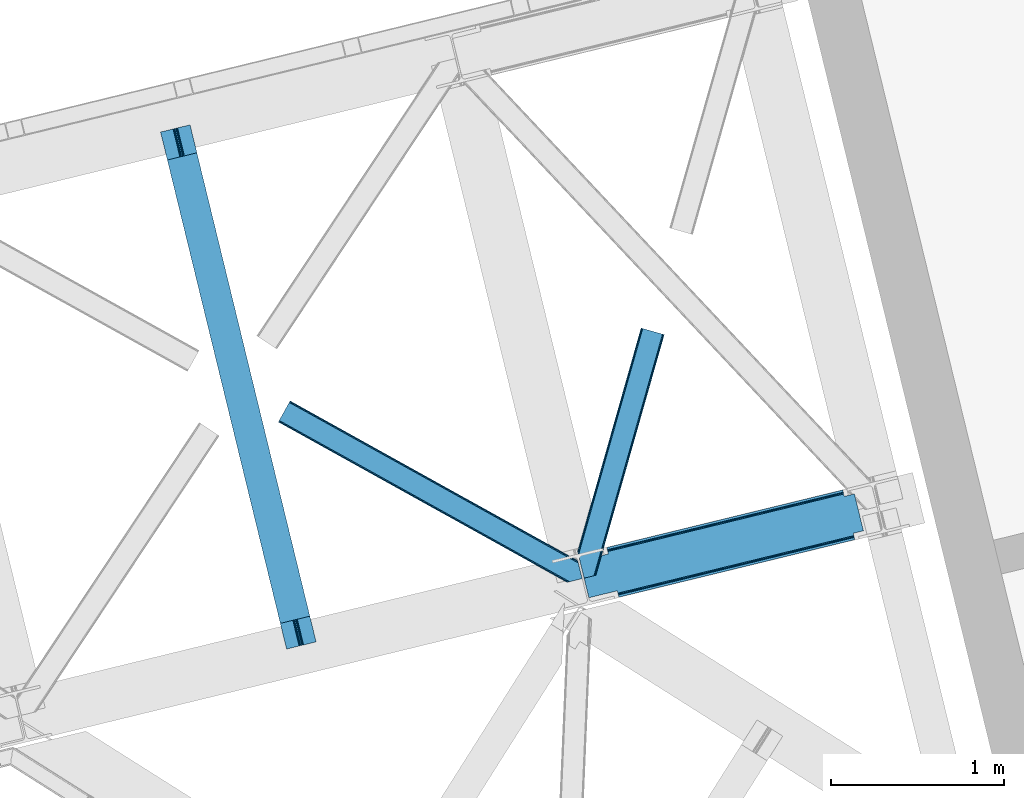
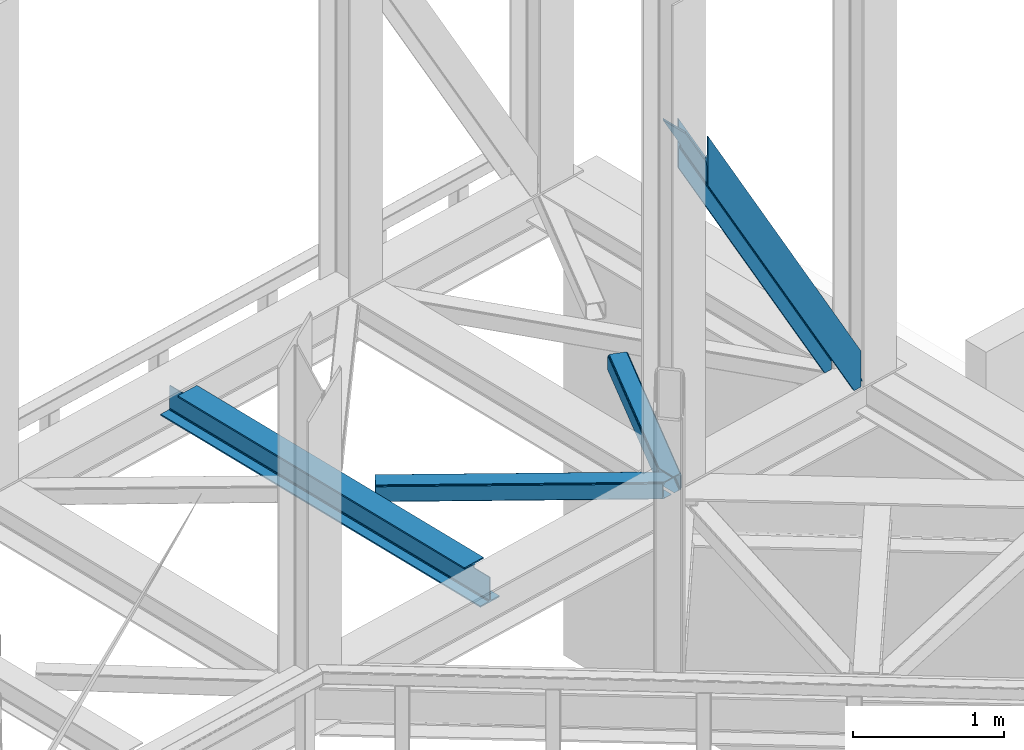
# One storey, part 83 of 92: 3 members, 1 beam.
"""IFC4 building model written with IfcOpenShell, lengths in millimetres."""

from ifc_helpers import new_model, entity, si_unit, converted_unit, derived_unit, direction, frame, origin, place, context, subcontext, project, spatial, triangles, polygons, material, type_object, element, save


model = new_model("IFC4")

# Units and contexts
model_context = context("Model", 3, precision=0.01, world=origin(), true_north=direction((6.12303176911189e-17, 1.0)))
plan_context = context("Plan", 3, precision=0.01, world=origin(), true_north=direction((6.12303176911189e-17, 1.0)))
body_context = subcontext(model_context, "Body", "Model", "MODEL_VIEW")
ifc_project = project(units=[si_unit("LENGTHUNIT", "METRE", prefix="MILLI"), si_unit("AREAUNIT", "SQUARE_METRE"), si_unit("VOLUMEUNIT", "CUBIC_METRE"), converted_unit("PLANEANGLEUNIT", "DEGREE", entity("IfcRatioMeasure", 0.0174532925199433), si_unit("PLANEANGLEUNIT", "RADIAN"), dimensions=[0, 0, 0, 0, 0, 0, 0]), si_unit("MASSUNIT", "GRAM", prefix="KILO"), derived_unit("MASSDENSITYUNIT", [(si_unit("MASSUNIT", "GRAM", prefix="KILO"), 1), (si_unit("LENGTHUNIT", "METRE"), -3)]), derived_unit("MOMENTOFINERTIAUNIT", [(si_unit("LENGTHUNIT", "METRE"), 4)]), si_unit("TIMEUNIT", "SECOND"), si_unit("FREQUENCYUNIT", "HERTZ"), si_unit("THERMODYNAMICTEMPERATUREUNIT", "DEGREE_CELSIUS"), derived_unit("THERMALTRANSMITTANCEUNIT", [(si_unit("MASSUNIT", "GRAM", prefix="KILO"), 1), (si_unit("THERMODYNAMICTEMPERATUREUNIT", "KELVIN"), -1), (si_unit("TIMEUNIT", "SECOND"), -3)]), derived_unit("VOLUMETRICFLOWRATEUNIT", [(si_unit("LENGTHUNIT", "METRE"), 3), (si_unit("TIMEUNIT", "SECOND"), -1)]), derived_unit("MASSFLOWRATEUNIT", [(si_unit("MASSUNIT", "GRAM", prefix="KILO"), 1), (si_unit("TIMEUNIT", "SECOND"), -1)]), derived_unit("ROTATIONALFREQUENCYUNIT", [(si_unit("TIMEUNIT", "SECOND"), -1)]), si_unit("ELECTRICCURRENTUNIT", "AMPERE"), si_unit("ELECTRICVOLTAGEUNIT", "VOLT"), si_unit("POWERUNIT", "WATT"), si_unit("FORCEUNIT", "NEWTON", prefix="KILO"), si_unit("ILLUMINANCEUNIT", "LUX"), si_unit("LUMINOUSFLUXUNIT", "LUMEN"), si_unit("LUMINOUSINTENSITYUNIT", "CANDELA"), derived_unit("USERDEFINED", [(si_unit("MASSUNIT", "GRAM", prefix="KILO"), -1), (si_unit("LENGTHUNIT", "METRE"), -2), (si_unit("TIMEUNIT", "SECOND"), 3), (si_unit("LUMINOUSFLUXUNIT", "LUMEN"), 1)]), derived_unit("LINEARVELOCITYUNIT", [(si_unit("LENGTHUNIT", "METRE"), 1), (si_unit("TIMEUNIT", "SECOND"), -1)]), si_unit("PRESSUREUNIT", "PASCAL"), derived_unit("USERDEFINED", [(si_unit("LENGTHUNIT", "METRE"), -2), (si_unit("MASSUNIT", "GRAM", prefix="KILO"), 1), (si_unit("TIMEUNIT", "SECOND"), -2)]), derived_unit("LINEARFORCEUNIT", [(si_unit("MASSUNIT", "GRAM", prefix="KILO"), 1), (si_unit("LENGTHUNIT", "METRE"), 1), (si_unit("TIMEUNIT", "SECOND"), -2), (si_unit("LENGTHUNIT", "METRE"), -1)]), derived_unit("PLANARFORCEUNIT", [(si_unit("MASSUNIT", "GRAM", prefix="KILO"), 1), (si_unit("LENGTHUNIT", "METRE"), 1), (si_unit("TIMEUNIT", "SECOND"), -2), (si_unit("LENGTHUNIT", "METRE"), -2)])], contexts=[model_context, plan_context])

# Site, building, storey
site_placement = place(None, origin())
site = spatial("IfcSite", under=ifc_project, at=site_placement, CompositionType="ELEMENT")
building_placement = place(site_placement, origin())
building = spatial("IfcBuilding", under=site, at=building_placement, CompositionType="ELEMENT")
storey_placement = place(building_placement, frame((0.0, 0.0, 15900.0)))
storey = spatial("IfcBuildingStorey", under=building, at=storey_placement, Name="05", CompositionType="ELEMENT", Elevation=15900.0)

# Beam
ifc_material = material(Name="Metal painted (White)")
beam_type = type_object("IfcBeamType", PredefinedType="BEAM")
beam_placement = place(storey_placement, frame((-4605.05, 16672.4, 3441.0)))
element("IfcBeam", 1, at=beam_placement, inside=storey, type_object=beam_type, material=ifc_material, ObjectType="Steel Beam", PredefinedType="BEAM", context=body_context, shape_type="Tessellation", body=[
    polygons([(896.722476515621, 41.4445662733103, 11.000000000004), (896.72247651562, 41.4445662733103, 2.16573425859679e-12), (170.02161017477, 3022.65205668042, 2.16573425859679e-12), (170.02161017477, 3022.65205668042, 11.000000000004), (830.656936562001, 25.3403919499699, 11.000000000004), (103.95607022115, 3006.54788235708, 11.000000000004), (824.708186540703, 23.8903211957417, 12.2179274798217), (98.007320199853, 3005.09781160286, 12.2179274798217), (819.665079784591, 22.6610105689216, 15.6862915010257), (92.9642134437405, 3003.86850097604, 15.6862915010257), (816.295383581418, 21.839611468714, 20.8770650821657), (89.5945172405684, 3003.04710187583, 20.8770650821657), (815.112103631724, 21.5511744621227, 27.0000000000047), (88.4112372908739, 3002.75866486924, 27.0000000000047), (81.6103728838909, 3001.1008822183, 27.0000000000047), (81.6103728838915, 3001.10088221831, 203.000000000006), (88.4112372908706, 3002.75866486924, 203.000000000006), (5.41433564649196e-13, 2981.20749040711, 2.16573425859679e-12), (2.16573425859679e-12, 2981.20749040711, 10.9999999999997), (66.0655399536302, 2997.31166473046, 11.000000000004), (72.0142899749205, 2998.76173548468, 12.2179274798195), (77.0573967310308, 2999.99104611151, 15.6862915010192), (80.427092934211, 3000.81244521171, 20.8770650821657), (815.112103631721, 21.5511744621206, 203.000000000006), (808.311239224742, 19.8933918111897, 203.000000000006), (808.311239224741, 19.8933918111897, 27.0000000000047), (807.127959275061, 19.6049548046028, 20.8770650821657), (803.75826307188, 18.7835557043952, 15.6862915010192), (798.71515631577, 17.5542450775707, 12.2179274798195), (792.76640629448, 16.104174323349, 11.000000000004), (726.700866340852, 2.16573425859679e-12, 10.9999999999997), (726.700866340851, 2.16573425859679e-12, 2.16573425859679e-12), (779.142354126241, 169.113117828151, 203.069793472056), (127.487542634277, 2842.45257527589, 203.000000000006), (127.710423423425, 2841.53823284147, 203.617301946336), (127.723337667946, 2841.48525286857, 217.000003693143), (778.997150924595, 169.708652488344, 217.000003676718), (778.998021532492, 169.705081047464, 204.00000679514), (772.432053048639, 167.083518913905, 203.006342977999), (772.209205347559, 167.99787105405, 203.617301946336), (772.196291103036, 168.050851026943, 217.000003693143), (120.922477846387, 2839.82745140717, 217.000003676718), (120.921607238492, 2839.83102284805, 204.00000679514), (120.77730764944, 2840.42299574862, 203.076120467494), (120.686678227296, 2840.79479262496, 203.000000000006), (780.180635648643, 169.996249461788, 223.122939328039), (783.549632057316, 170.820519285667, 228.313710402595), (788.592267461342, 172.051763510973, 231.782072735464), (794.540846332051, 173.502536365655, 232.999999602236), (860.606297197569, 189.607076149589, 232.999999283132), (860.604823861134, 189.613120126462, 243.999994005812), (690.583442957211, 148.167613329572, 243.999994827032), (690.58491629365, 148.161569352698, 233.000000104353), (756.650367159178, 164.266109136635, 232.999999785253), (762.599272287504, 165.715543604856, 231.782072861016), (767.642836794641, 166.94297642799, 228.313710479427), (771.01322370438, 167.761542085424, 223.12293937232), (119.738993122354, 2839.53985443373, 223.122939328039), (116.369996713678, 2838.71558460985, 228.313710402595), (111.327361309646, 2837.48434038454, 231.782072735464), (105.378782438949, 2836.03356752986, 232.999999602236), (39.3133315734155, 2819.92902774593, 232.999999283128), (39.3148049098525, 2819.92298376905, 243.999994005812), (209.336185813776, 2861.36849056595, 243.999994827032), (209.334712477334, 2861.37453454282, 233.000000104357), (143.269261611822, 2845.26999475889, 232.999999785253), (137.320356483485, 2843.82056029066, 231.782072861012), (132.276791976353, 2842.59312746752, 228.313710479427), (128.906405066617, 2841.77456181009, 223.12293937232)], [[[1, 2, 3, 4]], [[5, 1, 4, 6]], [[7, 5, 6, 8]], [[9, 7, 8, 10]], [[11, 9, 10, 12]], [[13, 11, 12, 14]], [[15, 16, 17, 14, 12, 10, 8, 6, 4, 3, 18, 19, 20, 21, 22, 23]], [[13, 24, 25, 26, 27, 28, 29, 30, 31, 32, 2, 1, 5, 7, 9, 11]], [[2, 32, 18, 3]], [[32, 31, 19, 18]], [[31, 30, 20, 19]], [[27, 26, 15, 23]], [[28, 27, 23, 22]], [[29, 28, 22, 21]], [[30, 29, 21, 20]], [[33, 24, 13, 14, 17, 34, 35, 36, 37, 38]], [[25, 39, 40, 41, 42, 43, 44, 16, 15, 26]], [[39, 25, 24, 33]], [[45, 34, 17, 16]], [[41, 40, 38, 37, 46, 47, 48, 49, 50, 51, 52, 53, 54, 55, 56, 57]], [[42, 58, 59, 60, 61, 62, 63, 64, 65, 66, 67, 68, 69, 36, 35, 43]], [[46, 37, 36, 69]], [[47, 46, 69, 68]], [[48, 47, 68, 67]], [[49, 48, 67, 66]], [[50, 49, 66, 65]], [[51, 50, 65, 64]], [[52, 51, 64, 63]], [[53, 52, 63, 62]], [[54, 53, 62, 61]], [[55, 54, 61, 60]], [[56, 55, 60, 59]], [[57, 56, 59, 58]], [[41, 57, 58, 42]]], closed=False),
])

# Members
member_type_1 = type_object("IfcMemberType", PredefinedType="BRACE")
member_1_placement = place(storey_placement, frame((-2187.22, 16968.36, 3695.0)))
element("IfcMember", 2, at=member_1_placement, inside=storey, type_object=member_type_1, ObjectType="Steel Vertical Brace", PredefinedType="BRACE", context=body_context, shape_type="Tessellation", body=[
    polygons([(1523.65378747275, 333.032085942706, 0.0), (1582.15074591361, 347.2913384483, 0.0), (1585.22948512248, 334.661161692462, 0.0), (1526.73252668162, 320.401909186869, 0.0), (225.056603724429, 3.10463150599028, 2308.00987734577), (221.977864515554, 15.734808261831, 2308.00987734577), (221.977864515553, 15.734808261831, 2462.87833808595), (1582.1507459136, 347.291338448298, 51.1471308030944), (225.056603724427, 3.10463150599028, 2706.38533905685), (1585.22948512248, 334.661161692462, 294.654131773986), (217.71499484172, 33.2227453083746, 2515.66308676267), (216.294038283785, 39.0520576572275, 2515.66308676267), (216.294038283786, 39.0520576572275, 2498.73212963995), (217.714994841717, 33.2227453083768, 2498.73212963995), (219.34632444024, 26.5304015344206, 2496.00292226562), (220.72929889541, 20.8569064337962, 2488.23079722503), (221.653372883133, 17.065998205232, 2476.59899010114), (221.977864515552, 15.734808261831, 2706.38533905685), (221.977864515552, 15.734808261831, 2551.51687831667), (221.653372883138, 17.0659982052385, 2537.79622630148), (220.729298895404, 20.856906433807, 2526.16441917759), (219.346324440226, 26.5304015344141, 2518.39229413699), (1576.46691968183, 370.608587843693, 87.0009223570892), (1576.46691968183, 370.608587843693, 103.931879479809), (1577.88787623976, 364.779275494842, 103.9318794798), (1579.51920583827, 358.086931720883, 106.661086854137), (1580.90218029345, 352.413436620276, 114.433211894731), (1581.82625428118, 348.622528391703, 126.065019018618), (1582.15074591359, 347.291338448298, 139.785671033808), (1582.15074591359, 347.291338448298, 294.654131773986), (1581.82625428118, 348.622528391697, 64.8677828182753), (1580.90218029345, 352.413436620263, 76.4995899421711), (1579.51920583828, 358.086931720888, 84.2717149827655), (1577.88787623976, 364.779275494846, 87.0009223570848), (163.955471732923, 253.765062506492, 2498.73212963995), (162.534515174981, 259.594374855341, 2498.73212963995), (1522.70739657303, 591.15090504181, 87.0009223570935), (1524.12835313097, 585.321592692961, 87.0009223570935), (1524.73254220655, 584.95422971039, 86.1395897830593), (1525.33673128212, 584.586866727814, 85.2782572090295), (1573.43212950823, 596.310628884719, 0.0), (1625.29704387311, 383.540728151737, 0.0), (1577.201645647, 371.81696599483, 85.2782572090295), (1576.83428266443, 371.212776919264, 86.1395897830593), (215.689849208223, 39.4194206398013, 2499.59346221398), (215.085660132657, 39.7867836223773, 2500.45479478801), (51.8649143648901, 2.16573425859679e-12, 2789.86253966195), (6.76791955811495e-12, 212.769900732984, 2789.86253966195), (163.220745767773, 252.556684355359, 2500.45479478801), (163.588108750349, 253.160873430927, 2499.59346221398), (163.220745767771, 252.556684355359, 2517.38575191073), (5.41433564649196e-13, 212.769900732984, 2806.79349678468), (51.8649143648844, 0.0, 2806.79349678468), (215.085660132655, 39.7867836223773, 2517.38575191073), (215.68984920822, 39.4194206398013, 2516.5244193367), (1576.83428266442, 371.212776919264, 103.070546905779), (1577.201645647, 371.81696599483, 102.209214331749), (1634.84579817246, 385.868338036035, 0.0), (1582.98088380758, 598.638238769017, 0.0), (1525.33673128211, 584.586866727814, 102.209214331749), (1524.73254220655, 584.954229710388, 103.070546905779), (1524.12835313097, 585.321592692961, 103.931879479813), (1522.70739657303, 591.15090504181, 103.931879479809), (162.534515174979, 259.594374855341, 2515.66308676267), (163.955471732921, 253.765062506492, 2515.66308676267), (163.588108750346, 253.160873430927, 2516.5244193367), (160.903185576473, 266.286718629297, 2518.39229413699), (159.520211121304, 271.960213729915, 2526.16441917758), (158.596137133563, 275.751121958494, 2537.79622630147), (158.271645501151, 277.082311901891, 2551.51687831666), (158.271645501151, 277.082311901886, 2706.38533905685), (155.192906292277, 289.712488657727, 2706.38533905685), (155.192906292278, 289.712488657727, 2308.00987734577), (158.271645501152, 277.082311901886, 2308.00987734577), (158.271645501151, 277.082311901886, 2462.87833808595), (158.596137133566, 275.75112195849, 2476.59899010114), (159.520211121302, 271.960213729923, 2488.23079722503), (160.903185576474, 266.286718629303, 2496.00292226561), (1521.07606697452, 597.843248815768, 84.2717149827568), (1519.69309251934, 603.516743916388, 76.4995899421711), (1518.76901853161, 607.307652144959, 64.8677828182753), (1518.44452689919, 608.638842088356, 51.1471308030858), (1518.44452689919, 608.638842088356, 0.0), (1515.36578769032, 621.269018844194, 0.0), (1515.36578769032, 621.269018844194, 294.654131773986), (1518.44452689919, 608.638842088356, 294.654131773986), (1518.44452689919, 608.638842088358, 139.785671033799), (1518.76901853161, 607.307652144961, 126.065019018618), (1519.69309251935, 603.516743916384, 114.433211894731), (1521.07606697452, 597.843248815764, 106.661086854141), (1459.94756845834, 594.379589582763, 0.0), (1456.86882924947, 607.009766338602, 0.0)], [[[1, 2, 3, 4]], [[5, 6, 1, 4]], [[6, 7, 8, 2, 1]], [[9, 5, 4, 3, 10]], [[11, 12, 13, 14, 15, 16, 17, 7, 6, 5, 9, 18, 19, 20, 21, 22]], [[23, 24, 25, 26, 27, 28, 29, 30, 10, 3, 2, 8, 31, 32, 33, 34]], [[34, 33, 15, 14]], [[33, 32, 16, 15]], [[32, 31, 17, 16]], [[31, 8, 7, 17]], [[18, 9, 10, 30]], [[19, 18, 30, 29]], [[29, 28, 20, 19]], [[28, 27, 21, 20]], [[27, 26, 22, 21]], [[26, 25, 11, 22]], [[35, 36, 37, 38, 39, 40, 41, 42, 43, 44, 23, 34, 14, 13, 45, 46, 47, 48, 49, 50]], [[51, 52, 53, 54, 55, 12, 11, 25, 24, 56, 57, 58, 59, 60, 61, 62, 63, 64, 65, 66]], [[54, 53, 47, 46]], [[48, 47, 53, 52]], [[52, 51, 49, 48]], [[57, 43, 42, 58]], [[59, 58, 42, 41]], [[59, 41, 40, 60]], [[65, 64, 67, 68, 69, 70, 71, 72, 73, 74, 75, 76, 77, 78, 36, 35]], [[62, 38, 37, 79, 80, 81, 82, 83, 84, 85, 86, 87, 88, 89, 90, 63]], [[82, 81, 76, 75]], [[81, 80, 77, 76]], [[80, 79, 78, 77]], [[79, 37, 36, 78]], [[75, 74, 91, 83, 82]], [[92, 84, 83, 91]], [[74, 73, 92, 91]], [[73, 72, 85, 84, 92]], [[63, 90, 67, 64]], [[90, 89, 68, 67]], [[89, 88, 69, 68]], [[88, 87, 70, 69]], [[71, 70, 87, 86]], [[72, 71, 86, 85]]], closed=False),
])
member_type_2 = type_object("IfcMemberType", PredefinedType="BRACE")
member_2_placement = place(storey_placement, frame((-3925.98, 17057.18, 3510.02)))
element("IfcMember", 3, at=member_2_placement, inside=storey, type_object=member_type_2, ObjectType="Steel Horizontal Brace", PredefinedType="BRACE", context=body_context, shape_type="Tessellation", body=[
    triangles([(1726.38590240479, 124.059869384764, 129.196765136719), (1725.95627746582, 125.821389770506, 122.499499511719), (67.3144958496091, 1045.27805786133, 129.196765136719), (67.9638748168945, 1046.44310302734, 122.499499511719), (1727.60908355713, 119.041571044923, 134.87548828125), (65.475363922119, 1041.96198120117, 134.87548828125), (1729.43993110657, 111.53040161133, 138.668280029298), (62.7171020507813, 1036.99833068848, 138.668280029298), (1731.59939231873, 102.671640014647, 140.000756835936), (59.4673004150391, 1031.14403686523, 140.000756835936), (1725.95627746582, 125.821389770506, 17.5000946044929), (67.9638748168945, 1046.44310302734, 17.5000946044929), (1689.2107006073, 6.10660400390771, 140.000756835936), (8.49657440185547, 939.3461517334, 140.000756835936), (1751.44047775269, 21.2754455566392, 140.000756835936), (1679.62218704224, 3.76953735351708, 138.668280029298), (5.24677276611328, 933.491857910158, 138.668280029298), (1671.49782829285, 1.78942565917896, 134.87548828125), (2.48822021484375, 928.527044677736, 134.87548828125), (1666.06647377014, 0.465087890625, 129.196765136719), (0.644728088378542, 925.209805297851, 129.196765136719), (1664.15975875854, 0.0, 122.499499511719), (0.0, 924.045922851561, 122.499499511719), (1664.15975875854, 0.0, 17.5000946044929), (0.0, 924.045922851561, 17.5000946044929), (2.48822021484375, 928.527044677736, 5.12643127441333), (5.24677276611328, 933.491857910158, 1.33247680664135), (1584.29559288025, 56.7035156249985, 1.33247680664135), (1585.91380805969, 50.0643859863267, 4.50088806152417), (0.644728088378542, 925.209805297851, 10.8039916992202), (1586.87683067322, 48.7842315673843, 5.13573303222802), (1587.06024971008, 48.5423858642571, 5.2554931640625), (1587.43377342224, 48.0505554199226, 5.50082702636792), (1670.97823791504, 1.66268920898438, 5.50082702636792), (1666.06647377014, 0.465087890625, 10.8039916992202), (1586.28282623291, 49.5713928222649, 4.74505920410229), (1586.67146530151, 49.0574707031265, 5.00085754394604), (1582.13598632813, 65.5622772216811, 0.0), (8.49657440185547, 939.3461517334, 0.0), (1548.27744255066, 204.463101196288, 0.0), (59.4673004150391, 1031.14403686523, 0.0), (1544.52592735291, 220.383059692384, 4.86481933593677), (1544.64423408508, 220.684204101563, 5.1694519042976), (1545.00700263977, 220.667926025391, 5.33688354492188), (1545.36032409668, 220.652810668944, 5.50082702636792), (1544.54758300781, 220.687692260741, 5.12643127441333), (1544.49962081909, 219.960992431639, 4.50088806152417), (1546.11783599854, 213.323025512695, 1.33247680664135), (1726.19158287048, 124.856332397459, 12.5003997802742), (1724.64502029419, 124.700527954101, 10.9621215820298), (67.3144958496091, 1045.27805786133, 10.8039916992202), (65.475363922119, 1041.96198120117, 5.12643127441333), (1719.1595993042, 124.149398803711, 5.50082702636792), (62.7171020507813, 1036.99833068848, 1.33247680664135), (1744.64002075195, 19.6185699462876, 5.50082702636792), (1729.74921455383, 110.261874389649, 12.5003997802742), (1726.73631706238, 105.026147460936, 8.3320495605476), (1746.09501914978, 19.9731994628892, 7.00073547363354), (1727.30750312805, 97.0464019775391, 7.00073547363354), (62.0749900817868, 1035.84142456055, 12.1260040283196), (59.3210884094237, 1030.87893676758, 8.3320495605476), (1728.64317741394, 114.798806762694, 17.8035644531265), (1728.21355247498, 116.561489868163, 24.5008300781265), (63.9184822082516, 1039.15866394043, 17.8035644531265), (64.5635009765624, 1040.32370910644, 24.5008300781265), (56.0712867736816, 1025.02464294434, 7.00073547363354), (1699.23290863037, 8.54947814941261, 7.00073547363354), (11.8922973632812, 945.465545654297, 7.00073547363354), (1728.21355247498, 116.561489868163, 115.499926757813), (64.5635009765624, 1040.32370910644, 115.499926757813), (1729.86635856628, 109.780508422853, 127.875915527344), (1728.64317741394, 114.798806762694, 122.197192382813), (1733.85666732788, 93.411740112304, 133.00118408203), (1731.69720611572, 102.270501708983, 131.668707275392), (1751.44047775269, 21.2754455566392, 133.00118408203), (56.0712867736816, 1025.02464294434, 133.00118408203), (59.3210884094237, 1030.87893676758, 131.668707275392), (62.0749900817868, 1035.84142456055, 127.875915527344), (63.9184822082516, 1039.15866394043, 122.197192382813), (1699.23290863037, 8.54947814941261, 133.00118408203), (11.8922973632812, 945.465545654297, 133.00118408203), (5.88859405517542, 934.64760131836, 12.1260040283196), (8.64249572753897, 939.611251831055, 8.3320495605476), (3.40037384033167, 930.166479492189, 24.5008300781265), (4.04510192871066, 931.330361938475, 17.8035644531265), (5.88859405517542, 934.64760131836, 127.875915527344), (8.64249572753897, 939.611251831055, 131.668707275392), (3.40037384033167, 930.166479492189, 115.499926757813), (4.04510192871066, 931.330361938475, 122.197192382813), (1681.51553077698, 4.23113708496021, 127.875915527344), (1689.64439506531, 6.21241149902198, 131.668707275392), (1676.08868179321, 2.90796203613354, 122.197192382813), (1674.18182144165, 2.44287414550854, 115.499926757813), (1674.18182144165, 2.44287414550854, 24.5008300781265), (1681.51553077698, 4.23113708496021, 12.1260040283196), (1676.08868179321, 2.90796203613354, 17.8035644531265), (1689.64439506531, 6.21241149902198, 8.3320495605476)], [[1, 2, 3], [4, 3, 2], [5, 1, 6], [3, 6, 1], [7, 5, 8], [6, 8, 5], [9, 7, 10], [8, 10, 7], [2, 11, 12], [12, 4, 2], [13, 9, 14], [13, 15, 9], [10, 14, 9], [16, 13, 14], [14, 17, 16], [18, 16, 17], [17, 19, 18], [20, 18, 19], [19, 21, 20], [22, 20, 21], [21, 23, 22], [24, 22, 23], [23, 25, 24], [26, 27, 28], [28, 29, 26], [30, 26, 31], [31, 32, 30], [32, 33, 30], [34, 35, 33], [30, 33, 35], [36, 37, 26], [37, 31, 26], [26, 29, 36], [38, 28, 27], [27, 39, 38], [35, 24, 30], [25, 30, 24], [40, 38, 39], [39, 41, 40], [42, 36, 29], [43, 36, 42], [43, 37, 36], [44, 32, 31], [31, 43, 44], [31, 37, 43], [45, 33, 32], [32, 44, 45], [42, 46, 43], [29, 47, 42], [40, 47, 38], [40, 48, 47], [29, 38, 47], [29, 28, 38], [12, 49, 50], [12, 11, 49], [51, 50, 45], [45, 52, 51], [45, 43, 52], [50, 53, 45], [54, 52, 45], [48, 40, 41], [41, 54, 48], [47, 48, 54], [50, 51, 12], [33, 53, 34], [33, 45, 53], [53, 55, 34], [56, 53, 50], [57, 53, 56], [50, 49, 56], [58, 55, 59], [59, 53, 57], [53, 59, 55], [60, 61, 57], [60, 56, 62], [62, 63, 64], [65, 64, 63], [62, 64, 60], [57, 56, 60], [59, 57, 66], [61, 66, 57], [67, 59, 68], [67, 58, 59], [66, 68, 59], [63, 69, 65], [70, 65, 69], [71, 5, 7], [5, 71, 72], [73, 74, 9], [74, 71, 7], [75, 73, 15], [9, 15, 73], [74, 7, 9], [49, 62, 56], [11, 2, 63], [63, 62, 11], [49, 11, 62], [2, 69, 63], [72, 1, 5], [2, 1, 72], [69, 2, 72], [74, 73, 76], [76, 77, 74], [71, 74, 77], [77, 78, 71], [72, 71, 78], [78, 79, 72], [69, 72, 79], [79, 70, 69], [73, 80, 81], [80, 73, 75], [81, 76, 73], [51, 60, 64], [65, 4, 12], [51, 64, 12], [51, 52, 60], [64, 65, 12], [60, 52, 54], [66, 41, 39], [41, 61, 54], [61, 41, 66], [61, 60, 54], [3, 78, 6], [70, 4, 65], [4, 79, 3], [79, 4, 70], [3, 79, 78], [10, 76, 14], [8, 6, 78], [78, 77, 8], [77, 76, 10], [10, 8, 77], [82, 27, 26], [39, 68, 66], [39, 83, 68], [83, 39, 27], [82, 83, 27], [84, 25, 23], [30, 85, 82], [26, 30, 82], [85, 30, 25], [84, 85, 25], [17, 86, 19], [14, 76, 81], [81, 87, 14], [87, 86, 17], [17, 14, 87], [21, 19, 86], [23, 88, 84], [89, 23, 21], [23, 89, 88], [89, 21, 86], [90, 91, 16], [18, 90, 16], [92, 18, 20], [92, 22, 93], [18, 92, 90], [22, 92, 20], [91, 13, 16], [15, 80, 75], [15, 13, 80], [91, 80, 13], [22, 94, 93], [34, 95, 96], [96, 94, 24], [24, 94, 22], [96, 35, 34], [35, 96, 24], [55, 67, 34], [67, 97, 34], [97, 95, 34], [55, 58, 67], [97, 67, 68], [68, 83, 97], [95, 97, 83], [83, 82, 95], [96, 95, 82], [82, 85, 96], [94, 96, 85], [85, 84, 94], [93, 94, 88], [84, 88, 94], [92, 93, 89], [88, 89, 93], [90, 92, 86], [89, 86, 92], [91, 90, 87], [86, 87, 90], [80, 91, 81], [87, 81, 91]]),
])
member_type_3 = type_object("IfcMemberType", PredefinedType="BRACE")
member_3_placement = place(storey_placement, frame((-2200.6, 17081.3, 3510.02)))
element("IfcMember", 4, at=member_3_placement, inside=storey, type_object=member_type_3, ObjectType="Steel Horizontal Brace", PredefinedType="BRACE", context=body_context, shape_type="Tessellation", body=[
    triangles([(382.458631896973, 1437.45993347168, 140.000756835936), (376.014548492432, 1439.28889160157, 138.668280029298), (5.18718338012695, 133.445343017578, 138.668280029298), (8.40283012390137, 120.253125000003, 140.000756835936), (370.552672576904, 1440.83879699707, 134.87548828125), (2.46118698120108, 144.628381347658, 134.87548828125), (366.905947494507, 1441.87594299317, 129.196765136719), (0.639641189575286, 152.101181030273, 129.196765136719), (365.625211715698, 1442.23987426758, 122.499499511719), (0.0, 154.725439453126, 122.499499511719), (365.625211715698, 1442.23987426758, 17.5000946044929), (0.0, 154.725439453126, 17.5000946044929), (86.8012424468993, 11.9643859863281, 140.000756835936), (483.46365852356, 1408.77563781738, 140.000756835936), (37.7160118103025, 0.0, 140.000756835936), (500.297078704834, 1403.99453430176, 122.499499511719), (499.016342926025, 1404.35846557617, 129.196765136719), (106.348595809936, 16.7292114257834, 122.499499511719), (104.86191329956, 16.3664428710945, 129.196765136719), (495.369617843628, 1405.39561157227, 134.87548828125), (100.623509216308, 15.3339477539084, 134.87548828125), (489.9077419281, 1406.9466796875, 138.668280029298), (94.2839252471922, 13.7886932373076, 138.668280029298), (500.297078704834, 1403.99453430176, 17.5000946044929), (106.348595809936, 16.7292114257834, 17.5000946044929), (370.552672576904, 1440.83879699707, 5.12643127441333), (376.014548492432, 1439.28889160157, 1.33247680664135), (64.4095859527588, 341.997729492188, 1.33247680664135), (366.905947494507, 1441.87594299317, 10.8039916992202), (57.6633407592772, 340.35364379883, 5.50082702636792), (1.58013610839816, 155.411444091798, 10.8039916992202), (0.350269317626953, 153.288317871094, 12.5003997802742), (6.16328659057626, 158.997271728516, 5.50082702636792), (382.458631896973, 1437.45993347168, 0.0), (71.8924140930176, 343.822036743164, 0.0), (101.030170440674, 15.4327789306662, 5.50082702636792), (149.676183700562, 186.73860168457, 5.50082702636792), (44.5164688110349, 1.65687561035156, 5.50082702636792), (109.170516586304, 352.90869140625, 5.50082702636792), (149.709902572632, 188.722201538087, 5.00085754394604), (489.9077419281, 1406.9466796875, 1.33247680664135), (495.369617843628, 1405.39561157227, 5.12643127441333), (149.739115905762, 190.703475952148, 4.50088806152417), (149.724436569214, 189.72214050293, 4.74854736328052), (147.329379272461, 200.588919067384, 1.33247680664135), (499.016342926025, 1404.35846557617, 10.8039916992202), (104.86191329956, 16.3664428710945, 10.8039916992202), (149.690717697144, 187.719937133792, 5.25316772460792), (483.46365852356, 1408.77563781738, 0.0), (144.113877868652, 213.779974365236, 0.0), (110.142114257812, 353.145886230472, 0.0), (109.541133499145, 352.999383544924, 5.42408752441406), (110.142114257812, 353.145886230472, 4.50088806152417), (43.0614704132081, 1.30224609375, 7.00073547363354), (14.8120319366453, 117.192846679689, 7.00073547363354), (10.8560234069823, 127.785223388673, 8.3320495605476), (5.64776573181143, 131.555923461914, 12.5003997802742), (377.289616012573, 1438.92844848633, 12.1260040283196), (373.638385391235, 1439.96326904297, 17.8035644531265), (4.00077323913547, 138.312487792969, 17.8035644531265), (389.191069793701, 1435.54725952149, 7.00073547363354), (382.751637268066, 1437.37738037109, 8.3320495605476), (372.357649612427, 1440.32720031738, 24.5008300781265), (3.36113204956064, 140.936746215823, 24.5008300781265), (78.9841323852538, 10.0586883544929, 7.00073547363354), (476.731220626831, 1410.68831176758, 7.00073547363354), (372.357649612427, 1440.32720031738, 115.499926757813), (3.36113204956064, 140.936746215823, 115.499926757813), (5.82231903076172, 130.839688110354, 127.875915527344), (4.00077323913547, 138.312487792969, 122.197192382813), (8.54831542968759, 119.656649780274, 131.668707275392), (11.763962173462, 106.464431762695, 133.00118408203), (37.7160118103025, 0.0, 133.00118408203), (373.638385391235, 1439.96326904297, 122.197192382813), (377.289616012573, 1438.92844848633, 127.875915527344), (382.751637268066, 1437.37738037109, 131.668707275392), (389.191069793701, 1435.54725952149, 133.00118408203), (78.9841323852538, 10.0586883544929, 133.00118408203), (476.731220626831, 1410.68831176758, 133.00118408203), (488.632529067993, 1407.30712280274, 12.1260040283196), (492.283905029297, 1406.27113952637, 17.8035644531265), (493.564640808105, 1405.90720825196, 24.5008300781265), (483.175158691406, 1408.8593536377, 8.3320495605476), (488.632529067993, 1407.30712280274, 127.875915527344), (493.564640808105, 1405.90720825196, 115.499926757813), (492.283905029297, 1406.27113952637, 122.197192382813), (483.175158691406, 1408.8593536377, 131.668707275392), (86.4623096466062, 11.8818328857451, 131.668707275392), (92.8063991546628, 13.4282501220732, 127.875915527344), (97.0402976989744, 14.4607452392593, 122.197192382813), (98.5314857482908, 14.8235137939482, 115.499926757813), (86.4623096466062, 11.8818328857451, 8.3320495605476), (97.0402976989744, 14.4607452392593, 17.8035644531265), (92.8063991546628, 13.4282501220732, 12.1260040283196), (98.5314857482908, 14.8235137939482, 24.5008300781265)], [[1, 2, 3], [3, 4, 1], [2, 5, 6], [6, 3, 2], [5, 7, 8], [8, 6, 5], [7, 9, 10], [10, 8, 7], [9, 11, 12], [12, 10, 9], [4, 13, 14], [13, 4, 15], [14, 1, 4], [16, 17, 18], [19, 18, 17], [17, 20, 19], [21, 19, 20], [20, 22, 21], [23, 21, 22], [22, 14, 23], [13, 23, 14], [24, 16, 25], [18, 25, 16], [26, 27, 28], [29, 26, 30], [11, 29, 31], [31, 12, 11], [31, 32, 12], [29, 30, 31], [33, 31, 30], [28, 30, 26], [27, 34, 35], [35, 28, 27], [36, 33, 37], [36, 38, 33], [30, 37, 33], [39, 37, 30], [40, 41, 42], [43, 41, 44], [40, 44, 41], [43, 45, 41], [46, 47, 37], [37, 42, 46], [37, 48, 42], [47, 36, 37], [46, 24, 25], [25, 47, 46], [49, 41, 50], [45, 50, 41], [51, 35, 34], [50, 51, 49], [34, 49, 51], [35, 30, 28], [35, 51, 52], [35, 52, 30], [52, 51, 53], [48, 37, 39], [44, 40, 53], [43, 44, 53], [53, 50, 43], [50, 53, 51], [45, 43, 50], [38, 54, 55], [33, 55, 56], [55, 33, 38], [57, 31, 33], [33, 56, 57], [32, 31, 57], [58, 59, 60], [60, 57, 58], [61, 62, 56], [56, 55, 61], [62, 58, 57], [57, 56, 62], [59, 63, 64], [64, 60, 59], [55, 65, 66], [65, 55, 54], [66, 61, 55], [63, 67, 68], [68, 64, 63], [69, 6, 70], [71, 72, 4], [72, 15, 4], [72, 73, 15], [3, 71, 4], [69, 3, 6], [69, 71, 3], [10, 64, 68], [8, 70, 6], [68, 70, 10], [70, 8, 10], [12, 64, 10], [32, 57, 60], [60, 64, 12], [12, 32, 60], [67, 74, 68], [70, 68, 74], [74, 75, 70], [69, 70, 75], [75, 76, 69], [71, 69, 76], [76, 77, 71], [72, 71, 77], [78, 72, 79], [78, 73, 72], [77, 79, 72], [46, 80, 81], [82, 16, 24], [46, 81, 24], [46, 42, 80], [81, 82, 24], [80, 42, 41], [66, 49, 34], [49, 83, 41], [83, 49, 66], [83, 80, 41], [17, 84, 20], [85, 16, 82], [16, 86, 17], [86, 16, 85], [17, 86, 84], [14, 79, 1], [22, 20, 84], [84, 87, 22], [87, 79, 14], [14, 22, 87], [58, 27, 26], [34, 61, 66], [34, 62, 61], [62, 34, 27], [58, 62, 27], [63, 11, 9], [29, 59, 58], [26, 29, 58], [59, 29, 11], [63, 59, 11], [2, 75, 5], [1, 79, 77], [77, 76, 1], [76, 75, 2], [2, 1, 76], [7, 5, 75], [9, 67, 63], [74, 9, 7], [9, 74, 67], [74, 7, 75], [23, 13, 88], [15, 78, 13], [78, 15, 73], [78, 88, 13], [89, 23, 88], [89, 21, 23], [19, 89, 90], [89, 19, 21], [18, 90, 91], [90, 18, 19], [65, 36, 92], [93, 94, 47], [94, 92, 36], [65, 38, 36], [38, 65, 54], [95, 93, 25], [47, 25, 93], [18, 95, 25], [95, 18, 91], [94, 36, 47], [82, 81, 95], [93, 95, 81], [81, 80, 93], [94, 93, 80], [80, 83, 94], [92, 94, 83], [83, 66, 92], [65, 92, 66], [85, 82, 95], [95, 91, 85], [79, 87, 88], [88, 78, 79], [87, 84, 89], [89, 88, 87], [84, 86, 90], [90, 89, 84], [86, 85, 91], [91, 90, 86]]),
])

save(model, "model.ifc")
